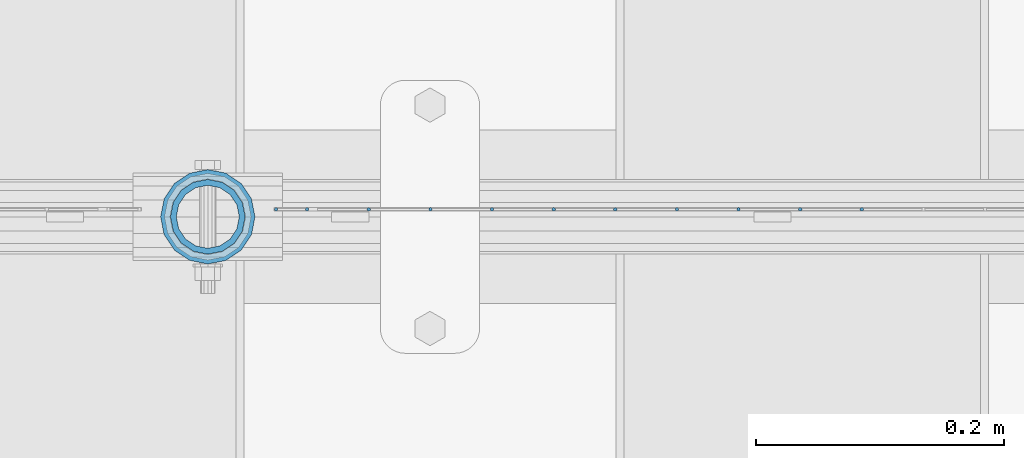
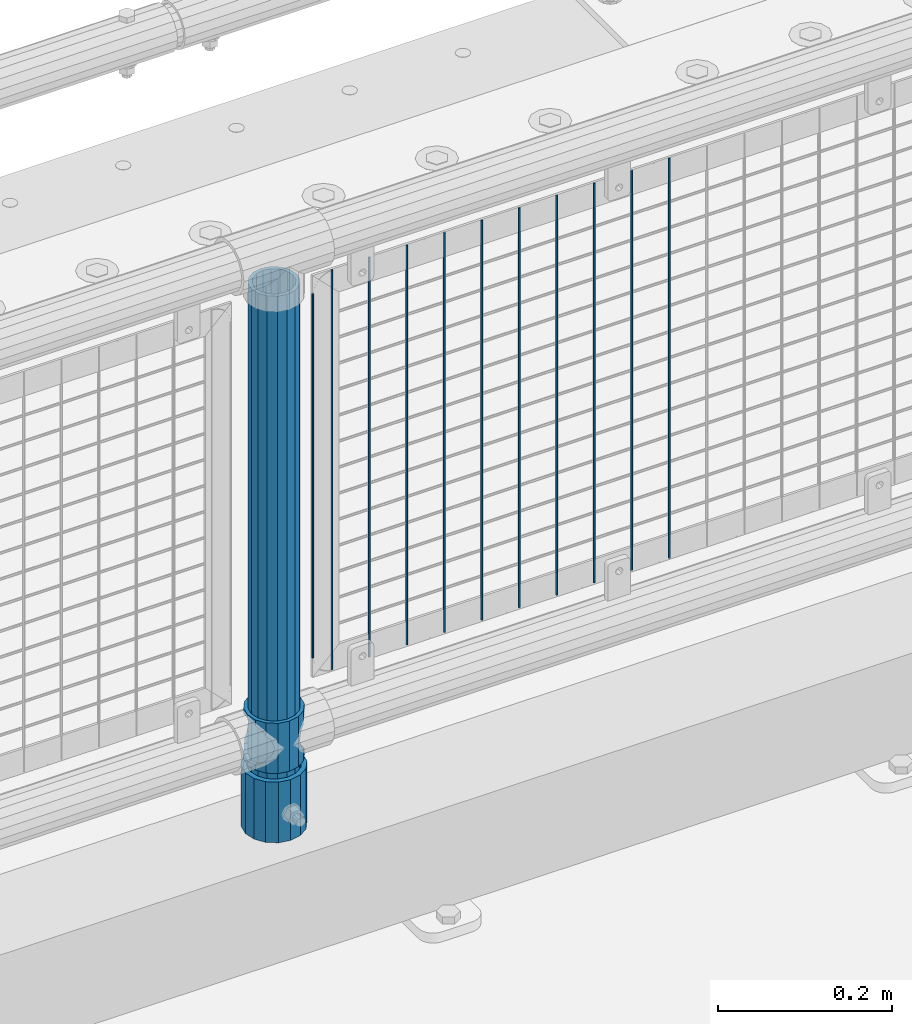
# One storey, part 81 of 208: 14 columns.
"""IFC2X3 building model written with IfcOpenShell, lengths in millimetres."""

from ifc_helpers import new_model, si_unit, frame, origin_with_axes, place, context, subcontext, project, spatial, faceted_brep, material, type_object, element, save


model = new_model("IFC2X3")

# Units and contexts
model_context = context("Model", 3, precision=1e-05, world=origin_with_axes())
body_context = subcontext(model_context, "Body", "Model", "MODEL_VIEW")
ifc_project = project(units=[si_unit("LENGTHUNIT", "METRE", prefix="MILLI"), si_unit("AREAUNIT", "SQUARE_METRE"), si_unit("VOLUMEUNIT", "CUBIC_METRE"), si_unit("MASSUNIT", "GRAM", prefix="KILO"), si_unit("TIMEUNIT", "SECOND"), si_unit("PLANEANGLEUNIT", "RADIAN"), si_unit("SOLIDANGLEUNIT", "STERADIAN"), si_unit("THERMODYNAMICTEMPERATUREUNIT", "DEGREE_CELSIUS"), si_unit("LUMINOUSINTENSITYUNIT", "LUMEN")], contexts=[model_context])

# Site, building, storey
site_placement = place(None, origin_with_axes())
site = spatial("IfcSite", under=ifc_project, at=site_placement, CompositionType="ELEMENT")
building_placement = place(site_placement, origin_with_axes())
building = spatial("IfcBuilding", under=site, at=building_placement, Name="Standard", CompositionType="ELEMENT")
storey_placement = place(building_placement, origin_with_axes())
storey = spatial("IfcBuildingStorey", under=building, at=storey_placement, Name="Undefined", CompositionType="ELEMENT", Elevation=0.0)

# Columns
ifc_material_1 = material()
column_type_1 = type_object("IfcColumnType", PredefinedType="NOTDEFINED")
column_1_placement = place(storey_placement, frame((-29029.0000001958, 4664.5, 168.019999999998), z_axis=(0.0, 1.0, 0.0), x_axis=(0.0, 0.0, 1.0)))
element("IfcColumn", 1, at=column_1_placement, inside=storey, type_object=column_type_1, material=ifc_material_1, context=body_context, shape_type="Brep", body=[
    faceted_brep([(0.0, -31.75, 0.0), (0.0, -29.3331751572332, 12.1501989775916), (85.0, -29.3331751572332, 12.1501989775916), (85.0, -31.75, 0.0), (0.0, -22.4506403026717, 22.4506403026726), (85.0, -22.4506403026717, 22.4506403026726), (0.0, -12.1501989775934, 29.3331751572332), (85.0, -12.1501989775934, 29.3331751572332), (0.0, 0.0, 31.75), (85.0, 0.0, 31.75), (0.0, 12.1501989775934, 29.3331751572332), (85.0, 12.1501989775934, 29.3331751572332), (0.0, 22.4506403026717, 22.4506403026726), (85.0, 22.4506403026717, 22.4506403026726), (0.0, 29.3331751572332, 12.1501989775916), (85.0, 29.3331751572332, 12.1501989775916), (0.0, 31.75, 0.0), (85.0, 31.75, 0.0), (0.0, 29.3331751572332, -12.1501989775916), (85.0, 29.3331751572332, -12.1501989775916), (0.0, 22.4506403026717, -22.4506403026726), (85.0, 22.4506403026717, -22.4506403026726), (0.0, 12.1501989775934, -29.3331751572332), (85.0, 12.1501989775934, -29.3331751572332), (0.0, 0.0, -31.75), (85.0, 0.0, -31.75), (0.0, -12.1501989775934, -29.3331751572332), (85.0, -12.1501989775934, -29.3331751572332), (0.0, -22.4506403026717, -22.4506403026726), (85.0, -22.4506403026717, -22.4506403026726), (0.0, -29.3331751572332, -12.1501989775916), (85.0, -29.3331751572332, -12.1501989775916), (0.0, -38.0499999999993, 0.0), (0.0, -35.1536162120537, -14.5611046014919), (85.0, -35.1536162120537, -14.5611046014919), (85.0, -38.0499999999993, 0.0), (0.0, -26.9054130241493, -26.9054130241484), (85.0, -26.9054130241493, -26.9054130241484), (0.0, -14.5611046014928, -35.1536162120547), (85.0, -14.5611046014928, -35.1536162120547), (0.0, 0.0, -38.0500000000002), (85.0, 0.0, -38.0500000000002), (0.0, 14.5611046014928, -35.1536162120547), (85.0, 14.5611046014928, -35.1536162120547), (0.0, 26.9054130241493, -26.9054130241484), (85.0, 26.9054130241493, -26.9054130241484), (0.0, 35.1536162120537, -14.5611046014919), (85.0, 35.1536162120537, -14.5611046014919), (0.0, 38.0499999999993, 0.0), (85.0, 38.0499999999993, 0.0), (0.0, 35.1536162120537, 14.5611046014919), (85.0, 35.1536162120537, 14.5611046014919), (0.0, 26.9054130241493, 26.9054130241484), (85.0, 26.9054130241493, 26.9054130241484), (0.0, 14.5611046014928, 35.1536162120547), (85.0, 14.5611046014928, 35.1536162120547), (0.0, 0.0, 38.0500000000002), (85.0, 0.0, 38.0500000000002), (0.0, -14.5611046014928, 35.1536162120547), (85.0, -14.5611046014928, 35.1536162120547), (0.0, -26.9054130241493, 26.9054130241484), (85.0, -26.9054130241493, 26.9054130241484), (0.0, -35.1536162120537, 14.5611046014919), (85.0, -35.1536162120537, 14.5611046014919)], [[[0, 1, 2, 3]], [[1, 4, 5, 2]], [[4, 6, 7, 5]], [[6, 8, 9, 7]], [[8, 10, 11, 9]], [[10, 12, 13, 11]], [[12, 14, 15, 13]], [[14, 16, 17, 15]], [[16, 18, 19, 17]], [[18, 20, 21, 19]], [[20, 22, 23, 21]], [[22, 24, 25, 23]], [[24, 26, 27, 25]], [[26, 28, 29, 27]], [[28, 30, 31, 29]], [[30, 0, 3, 31]], [[32, 33, 34, 35]], [[33, 36, 37, 34]], [[36, 38, 39, 37]], [[38, 40, 41, 39]], [[40, 42, 43, 41]], [[42, 44, 45, 43]], [[44, 46, 47, 45]], [[46, 48, 49, 47]], [[48, 50, 51, 49]], [[50, 52, 53, 51]], [[52, 54, 55, 53]], [[54, 56, 57, 55]], [[56, 58, 59, 57]], [[58, 60, 61, 59]], [[60, 62, 63, 61]], [[62, 32, 35, 63]], [[37, 39, 41, 43, 45, 47, 49, 51, 53, 55, 57, 59, 61, 63, 35, 34], [5, 7, 9, 11, 13, 15, 17, 19, 21, 23, 25, 27, 29, 31, 3, 2]], [[62, 60, 58, 56, 54, 52, 50, 48, 46, 44, 42, 40, 38, 36, 33, 32], [30, 28, 26, 24, 22, 20, 18, 16, 14, 12, 10, 8, 6, 4, 1, 0]]]),
])
ifc_material_2 = material(Name="Misc_Undefined")
column_type_2 = type_object("IfcColumnType", PredefinedType="NOTDEFINED")
column_2_placement = place(storey_placement, frame((-29029.0, 4664.5, 263.02), z_axis=(-1.0, 0.0, 0.0), x_axis=(0.0, 0.0, 1.0)))
element("IfcColumn", 2, at=column_2_placement, inside=storey, type_object=column_type_2, material=ifc_material_2, context=body_context, shape_type="Brep", body=[
    faceted_brep([(63.1897438117172, 11.6144421722802, -32.8397438117245), (63.1897438117172, 11.6144421722802, -28.0397438117143), (56.6106908090114, 21.4606908090118, -21.4606908090136), (56.6106908090114, 21.4606908090118, -27.1226768591077), (61.962379517676, 13.4513226476329, -32.4743655677739), (46.7644421722801, 28.0397438117179, -11.6144421722784), (46.7644421722801, 28.0397438117179, -20.0882031229921), (51.531042408003, 24.8548033587067, -24.8548033587067), (35.1500000000015, 30.35, 0.0), (35.1499999999996, 30.3500000000004, -16.6306603983685), (23.5355578277192, 28.0397438117179, -11.6144421722784), (23.5355578277192, 28.0397438117179, -20.0882031229921), (18.7689575919962, 24.8548033587067, -24.8548033587067), (13.6893091909879, 21.4606908090118, -21.4606908090136), (13.6893091909879, 21.4606908090118, -27.1226768591077), (8.33762048232325, 13.4513226476329, -32.4743655677739), (7.11025618828211, 11.6144421722802, -28.0397438117143), (7.11025618828211, 11.6144421722802, -32.8397438117245), (4.79999999999961, 0.0, -30.3499999999985), (4.79999999999961, 0.0, -35.1500000000015), (7.11025618828205, -11.6144421722802, -28.0397438117143), (7.11025618828205, -11.6144421722802, -32.8397438117245), (13.6893091909879, -21.4606908090118, -21.4606908090136), (13.6893091909879, -21.4606908090118, -27.1226768591005), (8.33762048232325, -13.4513226476329, -32.4743655677739), (23.5355578277191, -28.0397438117179, -11.6144421722784), (23.5355578277191, -28.0397438117179, -20.0882031229921), (18.7689575919962, -24.8548033587067, -24.8548033587067), (35.1500000000015, -30.35, 0.0), (35.1499999999996, -30.3500000000004, -16.6306603983685), (46.7644421722801, -28.0397438117179, -11.6144421722784), (46.7644421722801, -28.0397438117179, -20.0882031229921), (51.531042408003, -24.8548033587067, -24.8548033587067), (56.6106908090114, -21.4606908090118, -21.4606908090136), (56.6106908090114, -21.4606908090118, -27.1226768591005), (61.962379517675, -13.4513226476329, -32.4743655677739), (63.1897438117172, -11.6144421722802, -28.0397438117143), (63.1897438117172, -11.6144421722802, -32.8397438117245), (65.4999999999997, 0.0, -30.3499999999985), (65.4999999999997, 0.0, -35.1500000000015), (0.0, -28.0397438117179, -11.6144421722784), (0.0, -30.3500000000004, 0.0), (0.0, -21.4606908090118, -21.4606908090136), (0.0, -11.6144421722802, -28.0397438117143), (0.0, 0.0, -30.3499999999985), (0.0, 11.6144421722802, -28.0397438117143), (0.0, 21.4606908090118, -21.4606908090136), (0.0, 28.0397438117179, -11.6144421722784), (0.0, 30.3500000000004, 0.0), (0.0, 28.0397438117179, 11.6144421722784), (23.5355578277192, 28.0397438117179, 11.6144421722784), (0.0, 21.4606908090118, 21.4606908090136), (13.6893091909879, 21.4606908090118, 21.4606908090136), (0.0, 11.6144421722802, 28.0397438117143), (7.11025618828211, 11.6144421722802, 28.0397438117143), (0.0, 0.0, 30.3499999999985), (4.79999999999961, 0.0, 30.3499999999985), (0.0, -11.6144421722802, 28.0397438117143), (7.11025618828205, -11.6144421722802, 28.0397438117143), (0.0, -21.4606908090118, 21.4606908090136), (13.6893091909879, -21.4606908090118, 21.4606908090136), (0.0, -28.0397438117179, 11.6144421722784), (23.5355578277191, -28.0397438117179, 11.6144421722784), (0.0, -32.4743655677721, 13.4513226476338), (0.0, -35.1499999999996, 0.0), (70.2999999999993, -35.1499999999996, 0.0), (70.2999999999993, -32.4743655677721, 13.4513226476338), (0.0, 13.4513226476329, -32.4743655677739), (0.0, 24.8548033587067, -24.8548033587067), (0.0, 0.0, -35.1499999999996), (0.0, -13.4513226476329, -32.4743655677739), (0.0, -24.8548033587067, -24.8548033587067), (0.0, -24.8548033587067, 24.8548033587067), (0.0, -13.4513226476329, 32.4743655677739), (0.0, 0.0, 35.1499999999996), (0.0, 13.4513226476329, 32.4743655677739), (0.0, 24.8548033587067, 24.8548033587067), (0.0, 32.4743655677721, 13.4513226476338), (0.0, 35.1499999999996, 0.0), (0.0, 32.4743655677721, -13.4513226476338), (0.0, -32.4743655677721, -13.4513226476338), (70.2999999999993, 32.4743655677721, 13.4513226476338), (70.2999999999993, 35.1499999999996, 0.0), (70.2999999999993, 32.4743655677721, -13.4513226476338), (70.2999999999993, 24.8548033587067, -24.8548033587067), (70.2999999999993, 13.4513226476329, -32.4743655677739), (70.2999999999993, 0.0, -35.1500000000015), (70.2999999999993, -13.4513226476329, -32.4743655677739), (70.2999999999993, -24.8548033587067, -24.8548033587067), (70.2999999999993, -32.4743655677721, -13.4513226476338), (70.2999999999993, 28.0397438117179, 11.6144421722784), (70.2999999999993, 21.4606908090118, 21.4606908090136), (56.6106908090114, 21.4606908090118, 21.4606908090136), (46.7644421722801, 28.0397438117179, 11.6144421722784), (70.2999999999993, 11.6144421722802, 28.0397438117143), (63.1897438117172, 11.6144421722802, 28.0397438117143), (70.2999999999993, 0.0, 30.3499999999985), (65.4999999999997, 0.0, 30.3499999999985), (70.2999999999993, -11.6144421722802, 28.0397438117143), (63.1897438117172, -11.6144421722802, 28.0397438117143), (70.2999999999993, -21.4606908090118, 21.4606908090136), (56.6106908090114, -21.4606908090118, 21.4606908090136), (70.2999999999993, -28.0397438117179, 11.6144421722784), (46.7644421722801, -28.0397438117179, 11.6144421722784), (70.2999999999993, -11.6144421722802, -28.0397438117143), (70.2999999999993, 0.0, -30.3499999999985), (70.2999999999993, -21.4606908090118, -21.4606908090136), (70.2999999999993, -28.0397438117179, -11.6144421722784), (70.2999999999993, -30.3500000000004, 0.0), (70.2999999999993, 24.8548033587067, 24.8548033587067), (70.2999999999993, 13.4513226476329, 32.4743655677739), (70.2999999999993, 0.0, 35.1500000000015), (70.2999999999993, -13.4513226476329, 32.4743655677739), (70.2999999999993, -24.8548033587067, 24.8548033587067), (70.2999999999993, 30.3500000000004, 0.0), (70.2999999999993, 28.0397438117179, -11.6144421722784), (70.2999999999993, 21.4606908090118, -21.4606908090136), (70.2999999999993, 11.6144421722802, -28.0397438117143), (61.9623795176756, 13.4513226476329, 32.4743655677739), (51.531042408003, 24.8548033587067, 24.8548033587067), (56.6106908090114, 21.4606908090118, 27.1226768591005), (65.4999999999997, 0.0, 35.1500000000015), (63.1897438117172, 11.6144421722802, 32.8397438117172), (63.1897438117172, -11.6144421722802, 32.8397438117245), (61.962379517675, -13.4513226476329, 32.4743655677739), (56.6106908090114, -21.4606908090118, 27.1226768591077), (51.531042408003, -24.8548033587067, 24.8548033587067), (18.7689575919962, -24.8548033587067, 24.8548033587067), (46.7644421722801, -28.0397438117179, 20.0882031229776), (35.1499999999996, -30.3500000000004, 16.6306603983612), (23.5355578277191, -28.0397438117179, 20.0882031229776), (8.3376204823237, -13.4513226476329, 32.4743655677739), (13.6893091909879, -21.4606908090118, 27.1226768591077), (4.79999999999961, 0.0, 35.1500000000015), (7.11025618828205, -11.6144421722802, 32.8397438117245), (7.11025618828211, 11.6144421722802, 32.8397438117172), (8.3376204823237, 13.4513226476329, 32.4743655677739), (13.6893091909879, 21.4606908090118, 27.1226768591005), (18.7689575919962, 24.8548033587067, 24.8548033587067), (23.5355578277192, 28.0397438117179, 20.0882031229921), (35.1499999999996, 30.3500000000004, 16.6306603983685), (46.7644421722801, 28.0397438117179, 20.0882031229921)], [[[0, 1, 2, 3, 4]], [[3, 2, 5, 6, 7]], [[6, 5, 8, 9]], [[9, 8, 10, 11]], [[12, 11, 10, 13, 14]], [[15, 14, 13, 16, 17]], [[17, 16, 18, 19]], [[19, 18, 20, 21]], [[21, 20, 22, 23, 24]], [[23, 22, 25, 26, 27]], [[26, 25, 28, 29]], [[29, 28, 30, 31]], [[32, 31, 30, 33, 34]], [[35, 34, 33, 36, 37]], [[37, 36, 38, 39]], [[39, 38, 1, 0]], [[40, 41, 28, 25]], [[42, 40, 25, 22]], [[43, 42, 22, 20]], [[44, 43, 20, 18]], [[45, 44, 18, 16]], [[46, 45, 16, 13]], [[47, 46, 13, 10]], [[48, 47, 10, 8]], [[49, 48, 8, 50]], [[51, 49, 50, 52]], [[53, 51, 52, 54]], [[55, 53, 54, 56]], [[57, 55, 56, 58]], [[59, 57, 58, 60]], [[61, 59, 60, 62]], [[41, 61, 62, 28]], [[63, 64, 65, 66]], [[67, 68, 12, 14, 15]], [[69, 67, 15, 17, 19]], [[24, 70, 69, 19, 21]], [[27, 71, 70, 24, 23]], [[63, 72, 73, 74, 75, 76, 77, 78, 79, 68, 67, 69, 70, 71, 80, 64], [40, 42, 43, 44, 45, 46, 47, 48, 49, 51, 53, 55, 57, 59, 61, 41]], [[78, 77, 81, 82]], [[79, 78, 82, 83]], [[9, 11, 12, 68, 79, 83, 84, 7, 6]], [[7, 84, 85, 4, 3]], [[4, 85, 86, 39, 0]], [[87, 88, 32, 34, 35]], [[86, 87, 35, 37, 39]], [[88, 89, 80, 71, 27, 26, 29, 31, 32]], [[64, 80, 89, 65]], [[90, 91, 92, 93]], [[91, 94, 95, 92]], [[94, 96, 97, 95]], [[96, 98, 99, 97]], [[98, 100, 101, 99]], [[100, 102, 103, 101]], [[104, 105, 38, 36]], [[106, 104, 36, 33]], [[107, 106, 33, 30]], [[108, 107, 30, 28]], [[102, 108, 28, 103]], [[88, 87, 86, 85, 84, 83, 82, 81, 109, 110, 111, 112, 113, 66, 65, 89], [100, 98, 96, 94, 91, 90, 114, 115, 116, 117, 105, 104, 106, 107, 108, 102]], [[118, 110, 109, 119, 120]], [[121, 111, 110, 118, 122]], [[112, 111, 121, 123, 124]], [[113, 112, 124, 125, 126]], [[127, 72, 63, 66, 113, 126, 128, 129, 130]], [[131, 73, 72, 127, 132]], [[133, 74, 73, 131, 134]], [[75, 74, 133, 135, 136]], [[76, 75, 136, 137, 138]], [[119, 109, 81, 77, 76, 138, 139, 140, 141]], [[92, 120, 119, 141, 93]], [[95, 122, 118, 120, 92]], [[97, 121, 122, 95]], [[99, 123, 121, 97]], [[101, 125, 124, 123, 99]], [[103, 128, 126, 125, 101]], [[28, 129, 128, 103]], [[62, 130, 129, 28]], [[60, 132, 127, 130, 62]], [[58, 134, 131, 132, 60]], [[56, 133, 134, 58]], [[54, 135, 133, 56]], [[52, 137, 136, 135, 54]], [[50, 139, 138, 137, 52]], [[8, 140, 139, 50]], [[93, 141, 140, 8]], [[114, 90, 93, 8]], [[115, 114, 8, 5]], [[116, 115, 5, 2]], [[117, 116, 2, 1]], [[105, 117, 1, 38]]]),
])
column_type_3 = type_object("IfcColumnType", PredefinedType="NOTDEFINED")
column_3_placement = place(storey_placement, frame((-29029.0000001958, 4664.5, 168.019999999998), z_axis=(-1.0, 0.0, 0.0), x_axis=(0.0, 0.0, 1.0)))
element("IfcColumn", 3, at=column_3_placement, inside=storey, type_object=column_type_3, material=ifc_material_1, context=body_context, shape_type="Brep", body=[
    faceted_brep([(0.0, -25.3500000000004, 0.0), (0.0, -23.4203461491616, 9.70102501045403), (760.0, -23.4203461491616, 9.70102501045403), (760.0, -25.3500000000004, 0.0), (0.0, -17.9251569030794, 17.9251569030785), (760.0, -17.9251569030794, 17.9251569030785), (0.0, -9.70102501045494, 23.4203461491597), (760.0, -9.70102501045494, 23.4203461491597), (0.0, 0.0, 25.3499999999985), (760.0, 0.0, 25.3499999999985), (0.0, 9.70102501045494, 23.4203461491597), (760.0, 9.70102501045494, 23.4203461491597), (0.0, 17.9251569030794, 17.9251569030785), (760.0, 17.9251569030794, 17.9251569030785), (0.0, 23.4203461491616, 9.70102501045403), (760.0, 23.4203461491616, 9.70102501045403), (0.0, 25.3500000000004, 0.0), (760.0, 25.3500000000004, 0.0), (0.0, 23.4203461491616, -9.70102501045403), (760.0, 23.4203461491616, -9.70102501045403), (0.0, 17.9251569030794, -17.9251569030785), (760.0, 17.9251569030794, -17.9251569030785), (0.0, 9.70102501045494, -23.4203461491597), (760.0, 9.70102501045494, -23.4203461491597), (0.0, 0.0, -25.3499999999985), (760.0, 0.0, -25.3499999999985), (0.0, -9.70102501045494, -23.4203461491597), (760.0, -9.70102501045494, -23.4203461491597), (0.0, -17.9251569030794, -17.9251569030785), (760.0, -17.9251569030794, -17.9251569030785), (0.0, -23.4203461491616, -9.70102501045403), (760.0, -23.4203461491616, -9.70102501045403), (0.0, -30.1499999999996, 0.0), (0.0, -27.8549679052148, -11.5379054858058), (760.0, -27.8549679052148, -11.5379054858058), (760.0, -30.1499999999996, 0.0), (0.0, -21.3192694527743, -21.3192694527752), (760.0, -21.3192694527743, -21.3192694527752), (0.0, -11.5379054858076, -27.8549679052157), (760.0, -11.5379054858076, -27.8549679052157), (0.0, 0.0, -30.1500000000015), (760.0, 0.0, -30.1500000000015), (0.0, 11.5379054858076, -27.8549679052157), (760.0, 11.5379054858076, -27.8549679052157), (0.0, 21.3192694527743, -21.3192694527752), (760.0, 21.3192694527743, -21.3192694527752), (0.0, 27.8549679052157, -11.5379054858058), (760.0, 27.8549679052157, -11.5379054858058), (0.0, 30.1499999999996, 0.0), (760.0, 30.1499999999996, 0.0), (0.0, 27.8549679052157, 11.5379054858058), (760.0, 27.8549679052157, 11.5379054858058), (0.0, 21.3192694527743, 21.3192694527752), (760.0, 21.3192694527743, 21.3192694527752), (0.0, 11.5379054858076, 27.8549679052157), (760.0, 11.5379054858076, 27.8549679052157), (0.0, 0.0, 30.1500000000015), (760.0, 0.0, 30.1500000000015), (0.0, -11.5379054858076, 27.8549679052157), (760.0, -11.5379054858076, 27.8549679052157), (0.0, -21.3192694527743, 21.3192694527752), (760.0, -21.3192694527743, 21.3192694527752), (0.0, -27.8549679052157, 11.5379054858058), (760.0, -27.8549679052157, 11.5379054858058)], [[[0, 1, 2, 3]], [[1, 4, 5, 2]], [[4, 6, 7, 5]], [[6, 8, 9, 7]], [[8, 10, 11, 9]], [[10, 12, 13, 11]], [[12, 14, 15, 13]], [[14, 16, 17, 15]], [[16, 18, 19, 17]], [[18, 20, 21, 19]], [[20, 22, 23, 21]], [[22, 24, 25, 23]], [[24, 26, 27, 25]], [[26, 28, 29, 27]], [[28, 30, 31, 29]], [[30, 0, 3, 31]], [[32, 33, 34, 35]], [[33, 36, 37, 34]], [[36, 38, 39, 37]], [[38, 40, 41, 39]], [[40, 42, 43, 41]], [[42, 44, 45, 43]], [[44, 46, 47, 45]], [[46, 48, 49, 47]], [[48, 50, 51, 49]], [[50, 52, 53, 51]], [[52, 54, 55, 53]], [[54, 56, 57, 55]], [[56, 58, 59, 57]], [[58, 60, 61, 59]], [[60, 62, 63, 61]], [[62, 32, 35, 63]], [[37, 39, 41, 43, 45, 47, 49, 51, 53, 55, 57, 59, 61, 63, 35, 34], [5, 7, 9, 11, 13, 15, 17, 19, 21, 23, 25, 27, 29, 31, 3, 2]], [[62, 60, 58, 56, 54, 52, 50, 48, 46, 44, 42, 40, 38, 36, 33, 32], [30, 28, 26, 24, 22, 20, 18, 16, 14, 12, 10, 8, 6, 4, 1, 0]]]),
])
column_type_4 = type_object("IfcColumnType", Name="D3", PredefinedType="NOTDEFINED")
for number, where, z_axis, x_axis in (
    (4, (-28502.105, 4670.50000000001, 353.020000000006), (-1.0, 0.0, 0.0), (0.0, 0.0, 1.0)),
    (5, (-28551.76, 4670.50000000001, 353.020000000006), (-1.0, 0.0, 0.0), (0.0, 0.0, 1.0)),
    (6, (-28601.415, 4670.50000000001, 353.020000000006), (-1.0, 0.0, 0.0), (0.0, 0.0, 1.0)),
    (7, (-28651.07, 4670.50000000001, 353.020000000006), (-1.0, 0.0, 0.0), (0.0, 0.0, 1.0)),
    (8, (-28700.725, 4670.50000000001, 353.020000000006), (-1.0, 0.0, 0.0), (0.0, 0.0, 1.0)),
    (9, (-28750.38, 4670.50000000001, 353.020000000006), (-1.0, 0.0, 0.0), (0.0, 0.0, 1.0)),
    (10, (-28800.035, 4670.50000000001, 353.020000000006), (-1.0, 0.0, 0.0), (0.0, 0.0, 1.0)),
    (11, (-28849.6896551724, 4670.50000000001, 353.020000000006), (-1.0, 0.0, 0.0), (0.0, 0.0, 1.0)),
    (12, (-28899.3448275862, 4670.50000000001, 353.020000000006), (-0.999999999962839, 0.0, 8.62099999968473e-06), (8.62099999949798e-06, 0.0, 0.999999999962839)),
):
    element("IfcColumn", number, at=place(storey_placement, frame(where, z_axis=z_axis, x_axis=x_axis)), inside=storey, type_object=column_type_4, material=ifc_material_2, ObjectType="D3", context=body_context, shape_type="Brep", body=[
        faceted_brep([(0.0, -1.49999999999909, 3.63797880709171e-12), (-7.27595761418343e-12, -0.749999999999091, -1.29903810567669), (560.0, -0.75, -1.29903810567703), (560.0, -1.5, 0.0), (-3.63797880709171e-12, 0.750000000000909, -1.29903810567669), (560.0, 0.75, -1.29903810567703), (0.0, 1.50000000000182, 3.63797880709171e-12), (560.0, 1.5, 0.0), (-3.63797880709171e-12, 0.750000000000909, 1.29903810567669), (560.0, 0.75, 1.29903810567703), (-7.27595761418343e-12, -0.749999999999091, 1.29903810567669), (560.0, -0.75, 1.29903810567703)], [[[0, 1, 2, 3]], [[1, 4, 5, 2]], [[4, 6, 7, 5]], [[6, 8, 9, 7]], [[8, 10, 11, 9]], [[10, 0, 3, 11]], [[5, 7, 9, 11, 3, 2]], [[10, 8, 6, 4, 1, 0]]]),
    ])
column_4_placement = place(storey_placement, frame((-28974.0, 4670.50000000001, 378.020000000006), z_axis=(-1.0, 0.0, 0.0), x_axis=(0.0, 0.0, 1.0)))
element("IfcColumn", 13, at=column_4_placement, inside=storey, type_object=column_type_4, material=ifc_material_2, ObjectType="D3", context=body_context, shape_type="Brep", body=[
    faceted_brep([(0.0, -1.49999999999909, 3.63797880709171e-12), (-7.27595761418343e-12, -0.749999999999091, -1.29903810567669), (510.0, -0.75, -1.29903810567703), (510.0, -1.5, 0.0), (-3.63797880709171e-12, 0.750000000000909, -1.29903810567669), (510.0, 0.75, -1.29903810567703), (0.0, 1.50000000000182, 3.63797880709171e-12), (510.0, 1.5, 0.0), (-3.63797880709171e-12, 0.750000000000909, 1.29903810567669), (510.0, 0.75, 1.29903810567703), (-7.27595761418343e-12, -0.749999999999091, 1.29903810567669), (510.0, -0.75, 1.29903810567703)], [[[0, 1, 2, 3]], [[1, 4, 5, 2]], [[4, 6, 7, 5]], [[6, 8, 9, 7]], [[8, 10, 11, 9]], [[10, 0, 3, 11]], [[5, 7, 9, 11, 3, 2]], [[10, 8, 6, 4, 1, 0]]]),
])
column_5_placement = place(storey_placement, frame((-28949.0, 4670.50000000001, 353.020000000006), z_axis=(-1.0, 0.0, 0.0), x_axis=(0.0, 0.0, 1.0)))
element("IfcColumn", 14, at=column_5_placement, inside=storey, type_object=column_type_4, material=ifc_material_2, ObjectType="D3", context=body_context, shape_type="Brep", body=[
    faceted_brep([(0.0, -1.49999999999909, 3.63797880709171e-12), (-7.27595761418343e-12, -0.749999999999091, -1.29903810567669), (560.0, -0.75, -1.29903810567703), (560.0, -1.5, 0.0), (-3.63797880709171e-12, 0.750000000000909, -1.29903810567669), (560.0, 0.75, -1.29903810567703), (0.0, 1.50000000000182, 3.63797880709171e-12), (560.0, 1.5, 0.0), (-3.63797880709171e-12, 0.750000000000909, 1.29903810567669), (560.0, 0.75, 1.29903810567703), (-7.27595761418343e-12, -0.749999999999091, 1.29903810567669), (560.0, -0.75, 1.29903810567703)], [[[0, 1, 2, 3]], [[1, 4, 5, 2]], [[4, 6, 7, 5]], [[6, 8, 9, 7]], [[8, 10, 11, 9]], [[10, 0, 3, 11]], [[5, 7, 9, 11, 3, 2]], [[10, 8, 6, 4, 1, 0]]]),
])

save(model, "model.ifc")
